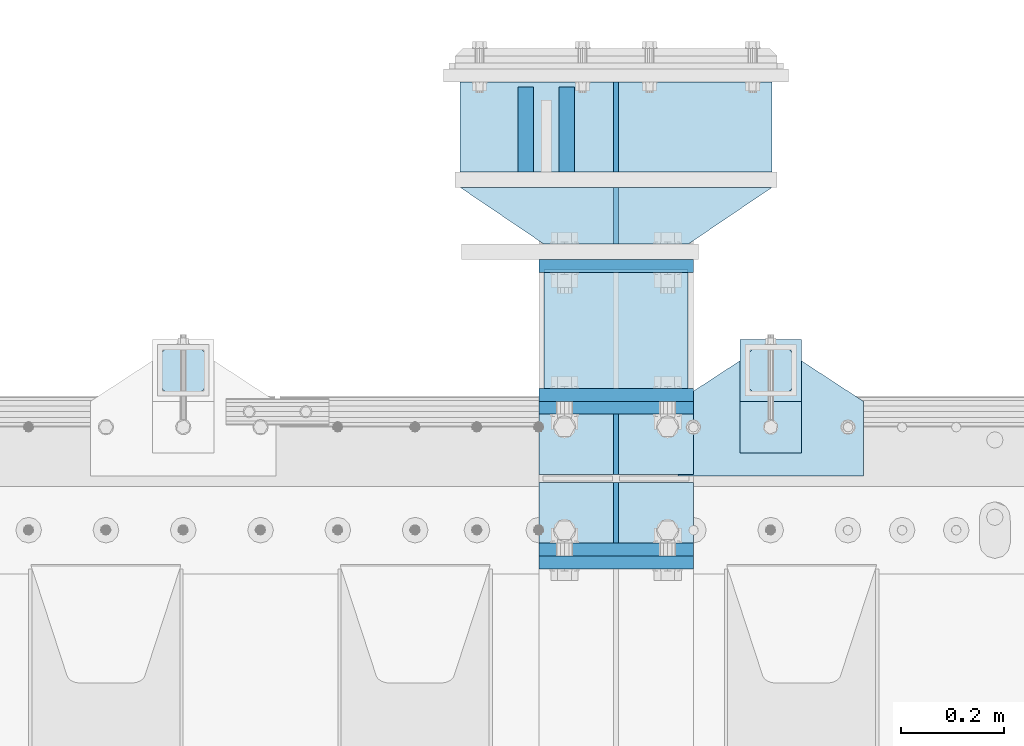
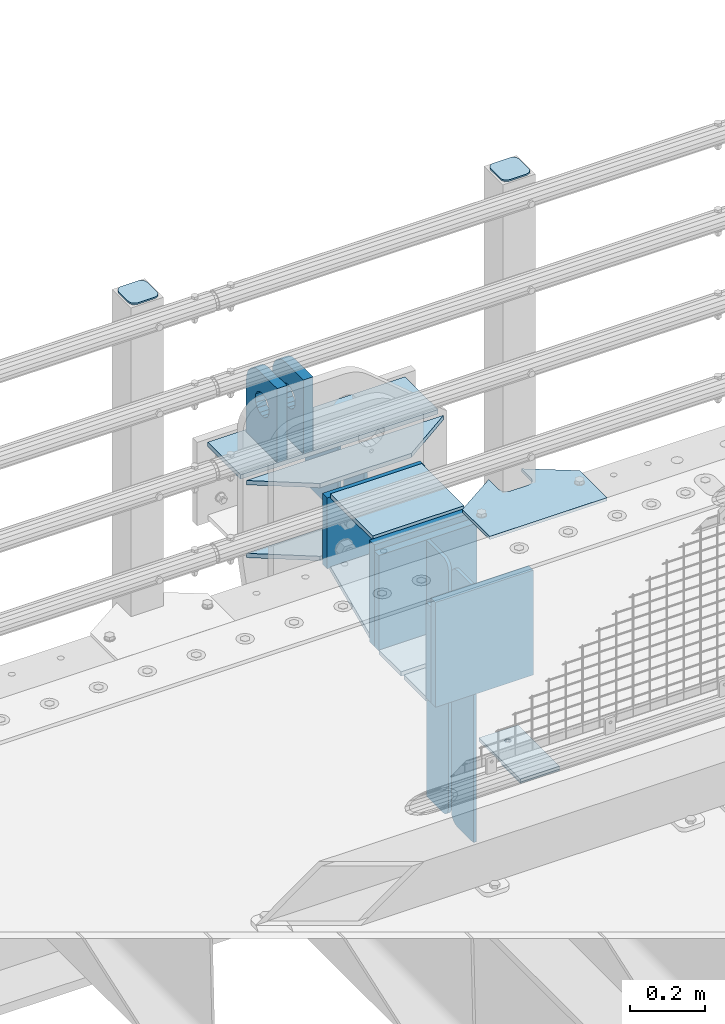
# One storey, part 175 of 193: 25 plates.
"""IFC2X3 building model written with IfcOpenShell, lengths in millimetres."""

from ifc_helpers import new_model, si_unit, frame, origin_with_axes, place, context, subcontext, project, spatial, faceted_brep, material, type_object, element, save


model = new_model("IFC2X3")

# Units and contexts
model_context = context("Model", 3, precision=1e-05, world=origin_with_axes())
body_context = subcontext(model_context, "Body", "Model", "MODEL_VIEW")
ifc_project = project(units=[si_unit("LENGTHUNIT", "METRE", prefix="MILLI"), si_unit("AREAUNIT", "SQUARE_METRE"), si_unit("VOLUMEUNIT", "CUBIC_METRE"), si_unit("MASSUNIT", "GRAM", prefix="KILO"), si_unit("TIMEUNIT", "SECOND"), si_unit("PLANEANGLEUNIT", "RADIAN"), si_unit("SOLIDANGLEUNIT", "STERADIAN"), si_unit("THERMODYNAMICTEMPERATUREUNIT", "DEGREE_CELSIUS"), si_unit("LUMINOUSINTENSITYUNIT", "LUMEN")], contexts=[model_context])

# Site, building, storey
site_placement = place(None, origin_with_axes())
site = spatial("IfcSite", under=ifc_project, at=site_placement, CompositionType="ELEMENT")
building_placement = place(site_placement, origin_with_axes())
building = spatial("IfcBuilding", under=site, at=building_placement, Name="Standard", CompositionType="ELEMENT")
storey_placement = place(building_placement, origin_with_axes())
storey = spatial("IfcBuildingStorey", under=building, at=storey_placement, Name="Undefined", CompositionType="ELEMENT", Elevation=0.0)

# Plates
ifc_material_1 = material(Name="STEEL/S355N")
plate_type_1 = type_object("IfcPlateType", PredefinedType="NOTDEFINED")
plate_1_placement = place(storey_placement, frame((-32200.0000000678, 30175.0000000043, -7.00001823835851), z_axis=(0.0, 1.0, 0.0), x_axis=(1.0, 0.0, 0.0)))
element("IfcPlate", 1, at=plate_1_placement, inside=storey, type_object=plate_type_1, material=ifc_material_1, context=body_context, shape_type="Brep", body=[
    faceted_brep([(0.0, -7.0, 0.0), (0.0, -7.0, 225.0), (0.0, 7.0, 225.0), (0.0, 7.0, 0.0), (280.0, -7.0, 225.0), (280.0, 7.0, 225.0), (280.0, -7.0, 0.0), (280.0, 7.0, 0.0)], [[[0, 1, 2, 3]], [[1, 4, 5, 2]], [[4, 6, 7, 5]], [[6, 0, 3, 7]], [[5, 7, 3, 2]], [[6, 4, 1, 0]]]),
])
plate_type_2 = type_object("IfcPlateType", PredefinedType="NOTDEFINED")
plate_2_placement = place(storey_placement, frame((-32060.0000000678, 30770.0000000043, -14.0000182383585), z_axis=(0.0, 0.0, -1.0), x_axis=(0.0, -1.0, 0.0)))
element("IfcPlate", 2, at=plate_2_placement, inside=storey, type_object=plate_type_2, material=ifc_material_1, context=body_context, shape_type="Brep", body=[
    faceted_brep([(0.0, -5.0, 0.0), (0.0, -5.0, 222.0), (0.0, 5.0, 222.0), (0.0, 5.0, 0.0), (175.0, -5.0, 222.0), (175.0, 5.0, 222.0), (175.0, -5.0, 0.0), (175.0, 5.0, 0.0)], [[[0, 1, 2, 3]], [[1, 4, 5, 2]], [[4, 6, 7, 5]], [[6, 0, 3, 7]], [[5, 7, 3, 2]], [[6, 4, 1, 0]]]),
])
plate_type_3 = type_object("IfcPlateType", PredefinedType="NOTDEFINED")
plate_3_placement = place(storey_placement, frame((-32155.5000000678, 30595.0000000043, -1.82383585070056e-05), z_axis=(0.0, 1.0, 0.0), x_axis=(0.0, 0.0, 1.0)))
element("IfcPlate", 3, at=plate_3_placement, inside=storey, type_object=plate_type_3, material=ifc_material_1, context=body_context, shape_type="Brep", body=[
    faceted_brep([(113.837049096103, -14.9999989400749, 106.162951053899), (113.837049096103, 15.0000010599251, 106.162950753896), (125.840713002497, 15.0000011401316, 114.183542552913), (125.840713002497, -14.9999988598684, 114.183542852916), (105.816457297088, -14.99999906011, 94.1592871475041), (105.816457297088, 15.00000093989, 94.1592868475018), (103.000000000005, -14.9999992017038, 80.0000001499975), (103.000000000005, 15.0000007982962, 79.9999998499952), (105.816457297088, -14.9999993432975, 65.8407131524909), (105.816457297088, 15.0000006567025, 65.8407128524887), (113.837049096103, -14.9999994633326, 53.8370492460963), (113.837049096103, 15.0000005366674, 53.837048946094), (125.840713002497, -14.9999995435392, 45.8164574470793), (125.840713002497, 15.0000004564608, 45.816457147077), (140.000000000005, -14.9999995717044, 43.0000001499975), (140.000000000005, 15.0000004282956, 42.9999998499952), (154.159286997514, -14.9999995435392, 45.8164574470793), (154.159286997514, 15.0000004564608, 45.816457147077), (166.162950903908, -14.9999994633326, 53.8370492460963), (166.162950903908, 15.0000005366674, 53.837048946094), (174.183542702923, -14.9999993432975, 65.8407131524909), (174.183542702923, 15.0000006567025, 65.8407128524887), (177.000000000005, -14.9999992017038, 80.0000001499975), (177.000000000005, 15.0000007982962, 79.9999998499952), (174.183542702923, -14.99999906011, 94.1592871475041), (174.183542702923, 15.00000093989, 94.1592868475018), (166.162950903908, -14.9999989400749, 106.162951053899), (166.162950903908, 15.0000010599251, 106.162950753896), (154.159286997514, -14.9999988598684, 114.183542852916), (154.159286997514, 15.0000011401316, 114.183542552913), (140.000000000005, -14.9999988317031, 117.000000149998), (140.000000000005, 15.0000011682969, 116.999999849995), (-1.40620068123098e-06, -15.0, 164.999999999996), (170.0, -15.0, 165.0), (170.0, 15.0, 165.0), (-1.40620068123098e-06, 15.0, 164.999999999996), (188.117333157176, -15.0, 162.614807840237), (188.117333157176, 15.0, 162.614807840237), (205.0, -15.0, 155.621778264911), (205.0, 15.0, 155.621778264911), (219.497474683058, -15.0, 144.497474683059), (219.497474683058, 15.0, 144.497474683059), (230.621778264911, -15.0, 130.0), (230.621778264911, 15.0, 130.0), (237.614807840235, -15.0, 113.117333157177), (237.614807840235, 15.0, 113.117333157177), (240.0, -15.0, 95.0), (240.0, 15.0, 95.0), (240.000015258789, -14.9999999999964, -2.07364792004228e-10), (240.000015258789, 15.0000000000036, -2.11002770811319e-10), (0.0, -15.0, 0.0), (0.0, 15.0, 0.0)], [[[0, 1, 2, 3]], [[4, 5, 1, 0]], [[6, 7, 5, 4]], [[8, 9, 7, 6]], [[10, 11, 9, 8]], [[12, 13, 11, 10]], [[14, 15, 13, 12]], [[16, 17, 15, 14]], [[18, 19, 17, 16]], [[20, 21, 19, 18]], [[22, 23, 21, 20]], [[24, 25, 23, 22]], [[26, 27, 25, 24]], [[28, 29, 27, 26]], [[30, 31, 29, 28]], [[3, 2, 31, 30]], [[32, 33, 34, 35]], [[33, 36, 37, 34]], [[36, 38, 39, 37]], [[38, 40, 41, 39]], [[40, 42, 43, 41]], [[42, 44, 45, 43]], [[44, 46, 47, 45]], [[46, 48, 49, 47]], [[48, 50, 51, 49]], [[34, 37, 39, 41, 43, 45, 47, 49, 51, 35], [19, 21, 23, 25, 27, 29, 31, 2, 1, 5, 7, 9, 11, 13, 15, 17]], [[50, 32, 35, 51]], [[48, 46, 44, 42, 40, 38, 36, 33, 32, 50], [10, 8, 6, 4, 0, 3, 30, 28, 26, 24, 22, 20, 18, 16, 14, 12]]]),
])
plate_4_placement = place(storey_placement, frame((-32235.5000000678, 30595.0000000043, -1.82383585070056e-05), z_axis=(0.0, 1.0, 0.0), x_axis=(0.0, 0.0, 1.0)))
element("IfcPlate", 4, at=plate_4_placement, inside=storey, type_object=plate_type_3, material=ifc_material_1, context=body_context, shape_type="Brep", body=[
    faceted_brep([(113.837049096103, -14.9999989400749, 106.162951053899), (113.837049096103, 15.0000010599251, 106.162950753896), (125.840713002497, 15.0000011401316, 114.183542552913), (125.840713002497, -14.9999988598684, 114.183542852916), (105.816457297088, -14.99999906011, 94.1592871475041), (105.816457297088, 15.00000093989, 94.1592868475018), (103.000000000005, -14.9999992017038, 80.0000001499975), (103.000000000005, 15.0000007982962, 79.9999998499952), (105.816457297088, -14.9999993432975, 65.8407131524909), (105.816457297088, 15.0000006567025, 65.8407128524887), (113.837049096103, -14.9999994633326, 53.8370492460963), (113.837049096103, 15.0000005366674, 53.837048946094), (125.840713002497, -14.9999995435392, 45.8164574470793), (125.840713002497, 15.0000004564608, 45.816457147077), (140.000000000005, -14.9999995717044, 43.0000001499975), (140.000000000005, 15.0000004282956, 42.9999998499952), (154.159286997514, -14.9999995435392, 45.8164574470793), (154.159286997514, 15.0000004564608, 45.816457147077), (166.162950903908, -14.9999994633326, 53.8370492460963), (166.162950903908, 15.0000005366674, 53.837048946094), (174.183542702923, -14.9999993432975, 65.8407131524909), (174.183542702923, 15.0000006567025, 65.8407128524887), (177.000000000005, -14.9999992017038, 80.0000001499975), (177.000000000005, 15.0000007982962, 79.9999998499952), (174.183542702923, -14.99999906011, 94.1592871475041), (174.183542702923, 15.00000093989, 94.1592868475018), (166.162950903908, -14.9999989400749, 106.162951053899), (166.162950903908, 15.0000010599251, 106.162950753896), (154.159286997514, -14.9999988598684, 114.183542852916), (154.159286997514, 15.0000011401316, 114.183542552913), (140.000000000005, -14.9999988317031, 117.000000149998), (140.000000000005, 15.0000011682969, 116.999999849995), (-1.40620068123098e-06, -15.0, 164.999999999996), (170.0, -15.0, 165.0), (170.0, 15.0, 165.0), (-1.40620068123098e-06, 15.0, 164.999999999996), (188.117333157176, -15.0, 162.614807840237), (188.117333157176, 15.0, 162.614807840237), (205.0, -15.0, 155.621778264911), (205.0, 15.0, 155.621778264911), (219.497474683058, -15.0, 144.497474683059), (219.497474683058, 15.0, 144.497474683059), (230.621778264911, -15.0, 130.0), (230.621778264911, 15.0, 130.0), (237.614807840235, -15.0, 113.117333157177), (237.614807840235, 15.0, 113.117333157177), (240.0, -15.0, 95.0), (240.0, 15.0, 95.0), (240.000015258789, -14.9999999999964, -2.07364792004228e-10), (240.000015258789, 15.0000000000036, -2.11002770811319e-10), (0.0, -15.0, 0.0), (0.0, 15.0, 0.0)], [[[0, 1, 2, 3]], [[4, 5, 1, 0]], [[6, 7, 5, 4]], [[8, 9, 7, 6]], [[10, 11, 9, 8]], [[12, 13, 11, 10]], [[14, 15, 13, 12]], [[16, 17, 15, 14]], [[18, 19, 17, 16]], [[20, 21, 19, 18]], [[22, 23, 21, 20]], [[24, 25, 23, 22]], [[26, 27, 25, 24]], [[28, 29, 27, 26]], [[30, 31, 29, 28]], [[3, 2, 31, 30]], [[32, 33, 34, 35]], [[33, 36, 37, 34]], [[36, 38, 39, 37]], [[38, 40, 41, 39]], [[40, 42, 43, 41]], [[42, 44, 45, 43]], [[44, 46, 47, 45]], [[46, 48, 49, 47]], [[48, 50, 51, 49]], [[34, 37, 39, 41, 43, 45, 47, 49, 51, 35], [19, 21, 23, 25, 27, 29, 31, 2, 1, 5, 7, 9, 11, 13, 15, 17]], [[50, 32, 35, 51]], [[48, 46, 44, 42, 40, 38, 36, 33, 32, 50], [10, 8, 6, 4, 0, 3, 30, 28, 26, 24, 22, 20, 18, 16, 14, 12]]]),
])
plate_type_4 = type_object("IfcPlateType", PredefinedType="NOTDEFINED")
plate_5_placement = place(storey_placement, frame((-32210.0000000678, 30162.5000000043, -340.000018238358), z_axis=(0.0, 0.0, 1.0), x_axis=(1.0, 0.0, 0.0)))
element("IfcPlate", 5, at=plate_5_placement, inside=storey, type_object=plate_type_4, material=ifc_material_1, context=body_context, shape_type="Brep", body=[
    faceted_brep([(0.0, -12.5, 0.0), (0.0, -12.5, 330.0), (0.0, 12.5, 330.0), (0.0, 12.5, 0.0), (300.0, -12.5, 330.0), (300.0, 12.5, 330.0), (300.0, -12.5, 0.0), (300.0, 12.5, 0.0)], [[[0, 1, 2, 3]], [[1, 4, 5, 2]], [[4, 6, 7, 5]], [[6, 0, 3, 7]], [[5, 7, 3, 2]], [[6, 4, 1, 0]]]),
])
plate_6_placement = place(storey_placement, frame((-32210.0, 29837.5, -340.000000000044), z_axis=(0.0, 0.0, 1.0), x_axis=(1.0, 0.0, 0.0)))
element("IfcPlate", 6, at=plate_6_placement, inside=storey, type_object=plate_type_4, material=ifc_material_1, context=body_context, shape_type="Brep", body=[
    faceted_brep([(0.0, -12.5, 0.0), (9.27684595808387e-10, -12.5, 340.0), (9.27684595808387e-10, 12.5, 340.0), (0.0, 12.5, 0.0), (300.0, -12.5, 340.0), (300.0, 12.5, 340.0), (300.0, -12.5, 0.0), (300.0, 12.5, 0.0)], [[[0, 1, 2, 3]], [[1, 4, 5, 2]], [[4, 6, 7, 5]], [[6, 0, 3, 7]], [[5, 7, 3, 2]], [[6, 4, 1, 0]]]),
])
for number, where, z_axis, x_axis in (
    (7, (-32210.0, 30137.5, -340.0), (0.0, 0.0, 1.0), (1.0, 0.0, 0.0)),
    (8, (-32210.0, 29862.5, -340.0), (0.0, 0.0, 1.0), (1.0, 0.0, 0.0)),
):
    element("IfcPlate", number, at=place(storey_placement, frame(where, z_axis=z_axis, x_axis=x_axis)), inside=storey, type_object=plate_type_4, material=ifc_material_1, context=body_context, shape_type="Brep", body=[
        faceted_brep([(0.0, -12.5, 0.0), (0.0, -12.5, 310.0), (0.0, 12.5, 310.0), (0.0, 12.5, 0.0), (300.0, -12.5, 310.0), (300.0, 12.5, 310.0), (300.0, -12.5, 0.0), (300.0, 12.5, 0.0)], [[[0, 1, 2, 3]], [[1, 4, 5, 2]], [[4, 6, 7, 5]], [[6, 0, 3, 7]], [[5, 7, 3, 2]], [[6, 4, 1, 0]]]),
    ])
plate_type_5 = type_object("IfcPlateType", PredefinedType="NOTDEFINED")
for number, where, z_axis, x_axis in (
    (9, (-32210.0, 29992.0, -343.0), (0.0, -1.0, 0.0), (1.0, 0.0, 0.0)),
    (10, (-32210.0, 30008.0, -343.0), (0.0, 1.0, 0.0), (1.0, 0.0, 0.0)),
):
    element("IfcPlate", number, at=place(storey_placement, frame(where, z_axis=z_axis, x_axis=x_axis)), inside=storey, type_object=plate_type_5, material=ifc_material_1, context=body_context, shape_type="Brep", body=[
        faceted_brep([(0.0, -7.0, 0.0), (0.0, -7.0, 117.0), (0.0, 7.0, 117.0), (0.0, 7.0, 0.0), (300.0, -7.0, 117.0), (300.0, 7.0, 117.0), (300.0, -7.0, 0.0), (300.0, 7.0, 0.0)], [[[0, 1, 2, 3]], [[1, 4, 5, 2]], [[4, 6, 7, 5]], [[6, 0, 3, 7]], [[5, 7, 3, 2]], [[6, 4, 1, 0]]]),
    ])
plate_type_6 = type_object("IfcPlateType", PredefinedType="NOTDEFINED")
for number, where, z_axis, x_axis in (
    (11, (-32060.0, 30008.0, -30.0), (0.0, 0.0, -1.0), (0.0, 1.0, 0.0)),
    (12, (-32060.0, 29992.0, -30.0), (0.0, 0.0, -1.0), (0.0, -1.0, 0.0)),
):
    element("IfcPlate", number, at=place(storey_placement, frame(where, z_axis=z_axis, x_axis=x_axis)), inside=storey, type_object=plate_type_6, material=ifc_material_1, context=body_context, shape_type="Brep", body=[
        faceted_brep([(0.0, -5.0, 30.0), (0.0, -5.0, 306.0), (0.0, 5.0, 306.0), (0.0, 5.0, 30.0), (117.0, -5.0, 306.0), (117.0, 5.0, 306.0), (117.0, -5.0, 0.0), (117.0, 5.0, 0.0), (30.0, -5.0, 0.0), (30.0, 5.0, 0.0), (24.7905546699913, -5.0, 0.455767409633758), (24.7905546699913, 5.0, 0.455767409633758), (19.7393957002314, -5.0, 1.80922137642275), (19.7393957002314, 5.0, 1.80922137642275), (15.0, -5.0, 4.01923788646684), (15.0, 5.0, 4.01923788646684), (10.7163717094045, -5.0, 7.01866670643066), (10.7163717094045, 5.0, 7.01866670643066), (7.01866670642994, -5.0, 10.7163717094038), (7.01866670642994, 5.0, 10.7163717094038), (4.01923788646673, -5.0, 15.0), (4.01923788646673, 5.0, 15.0), (1.80922137642119, -5.0, 19.7393957002299), (1.80922137642119, 5.0, 19.7393957002299), (0.455767409632244, -5.0, 24.7905546699921), (0.455767409632244, 5.0, 24.7905546699921)], [[[0, 1, 2, 3]], [[1, 4, 5, 2]], [[4, 6, 7, 5]], [[6, 8, 9, 7]], [[8, 10, 11, 9]], [[10, 12, 13, 11]], [[12, 14, 15, 13]], [[14, 16, 17, 15]], [[16, 18, 19, 17]], [[18, 20, 21, 19]], [[20, 22, 23, 21]], [[22, 24, 25, 23]], [[24, 0, 3, 25]], [[5, 7, 9, 11, 13, 15, 17, 19, 21, 23, 25, 3, 2]], [[24, 22, 20, 18, 16, 14, 12, 10, 8, 6, 4, 1, 0]]]),
    ])
for number, where, z_axis, x_axis in (
    (13, (-32060.0, 29992.0, -350.0), (0.0, 0.0, -1.0), (0.0, -1.0, 0.0)),
    (14, (-32060.0, 30008.0, -350.0), (0.0, 0.0, -1.0), (0.0, 1.0, 0.0)),
):
    element("IfcPlate", number, at=place(storey_placement, frame(where, z_axis=z_axis, x_axis=x_axis)), inside=storey, type_object=plate_type_6, material=ifc_material_1, context=body_context, shape_type="Brep", body=[
        faceted_brep([(0.0, -5.0, 0.0), (0.0, -5.0, 480.0), (0.0, 5.0, 480.0), (0.0, 5.0, 0.0), (0.455767409632244, -5.0, 485.209445330008), (0.455767409632244, 5.0, 485.209445330008), (1.80922137642119, -5.0, 490.26060429977), (1.80922137642119, 5.0, 490.26060429977), (4.01923788646673, -5.0, 495.0), (4.01923788646673, 5.0, 495.0), (7.01866670642994, -5.0, 499.283628290596), (7.01866670642994, 5.0, 499.283628290596), (10.7163717094045, -5.0, 502.981333293569), (10.7163717094045, 5.0, 502.981333293569), (15.0, -5.0, 505.980762113533), (15.0, 5.0, 505.980762113533), (19.7393957002314, -5.0, 508.190778623577), (19.7393957002314, 5.0, 508.190778623577), (24.7905546699913, -5.0, 509.544232590366), (24.7905546699913, 5.0, 509.544232590366), (30.0, -5.0, 510.0), (30.0, 5.0, 510.0), (117.0, -5.0, 510.0), (117.0, 5.0, 510.0), (117.0, -5.0, 0.0), (117.0, 5.0, 0.0)], [[[0, 1, 2, 3]], [[1, 4, 5, 2]], [[4, 6, 7, 5]], [[6, 8, 9, 7]], [[8, 10, 11, 9]], [[10, 12, 13, 11]], [[12, 14, 15, 13]], [[14, 16, 17, 15]], [[16, 18, 19, 17]], [[18, 20, 21, 19]], [[20, 22, 23, 21]], [[22, 24, 25, 23]], [[24, 0, 3, 25]], [[5, 7, 9, 11, 13, 15, 17, 19, 21, 23, 25, 3, 2]], [[24, 22, 20, 18, 16, 14, 12, 10, 8, 6, 4, 1, 0]]]),
    ])
ifc_material_2 = material(Name="STEEL/S355J2")
plate_type_7 = type_object("IfcPlateType", PredefinedType="NOTDEFINED")
plate_7_placement = place(storey_placement, frame((-31940.0, 30005.0, 5.00000000004911), z_axis=(0.0, 1.0, 0.0), x_axis=(1.0, 0.0, 0.0)))
element("IfcPlate", 15, at=plate_7_placement, inside=storey, type_object=plate_type_7, material=ifc_material_2, context=body_context, shape_type="Brep", body=[
    faceted_brep([(0.0, -5.0, 0.0), (2.31396552408114e-06, -5.0, 145.0), (2.31396552408114e-06, 5.0, 145.0), (0.0, 5.0, 0.0), (130.0, -5.0, 230.0), (130.0, 5.0, 230.0), (130.0, -5.0, 180.0), (130.0, 5.0, 180.0), (130.48036798992, -5.0, 175.122741949595), (130.48036798992, 5.0, 175.122741949595), (131.903011687216, -5.0, 170.432914190871), (131.903011687216, 5.0, 170.432914190871), (134.213259692435, -5.0, 166.110744174512), (134.213259692435, 5.0, 166.110744174512), (137.322330470335, -5.0, 162.322330470335), (137.322330470335, 5.0, 162.322330470335), (141.110744174512, -5.0, 159.213259692435), (141.110744174512, 5.0, 159.213259692435), (145.432914190871, -5.0, 156.903011687216), (145.432914190871, 5.0, 156.903011687216), (150.122741949595, -5.0, 155.48036798992), (150.122741949595, 5.0, 155.48036798992), (155.0, -5.0, 155.0), (155.0, 5.0, 155.0), (205.0, -5.0, 155.0), (205.0, 5.0, 155.0), (209.877258050405, -5.0, 155.48036798992), (209.877258050405, 5.0, 155.48036798992), (214.567085809129, -5.0, 156.903011687216), (214.567085809129, 5.0, 156.903011687216), (218.889255825488, -5.0, 159.213259692435), (218.889255825488, 5.0, 159.213259692435), (222.677669529665, -5.0, 162.322330470335), (222.677669529665, 5.0, 162.322330470335), (225.786740307565, -5.0, 166.110744174512), (225.786740307565, 5.0, 166.110744174512), (228.096988312784, -5.0, 170.432914190871), (228.096988312784, 5.0, 170.432914190871), (229.51963201008, -5.0, 175.122741949595), (229.51963201008, 5.0, 175.122741949595), (230.0, -5.0, 180.0), (230.0, 5.0, 180.0), (230.0, -5.0, 230.0), (230.0, 5.0, 230.0), (360.0, -5.0, 145.0), (360.0, 5.0, 145.0), (360.0, -5.0, -7.27595761418343e-12), (360.0, 5.0, -7.27595761418343e-12)], [[[0, 1, 2, 3]], [[1, 4, 5, 2]], [[4, 6, 7, 5]], [[6, 8, 9, 7]], [[8, 10, 11, 9]], [[10, 12, 13, 11]], [[12, 14, 15, 13]], [[14, 16, 17, 15]], [[16, 18, 19, 17]], [[18, 20, 21, 19]], [[20, 22, 23, 21]], [[22, 24, 25, 23]], [[24, 26, 27, 25]], [[26, 28, 29, 27]], [[28, 30, 31, 29]], [[30, 32, 33, 31]], [[32, 34, 35, 33]], [[34, 36, 37, 35]], [[36, 38, 39, 37]], [[38, 40, 41, 39]], [[40, 42, 43, 41]], [[42, 44, 45, 43]], [[44, 46, 47, 45]], [[46, 0, 3, 47]], [[5, 7, 9, 11, 13, 15, 17, 19, 21, 23, 25, 27, 29, 31, 33, 35, 37, 39, 41, 43, 45, 47, 3, 2]], [[46, 44, 42, 40, 38, 36, 34, 32, 30, 28, 26, 24, 22, 20, 18, 16, 14, 12, 10, 8, 6, 4, 1, 0]]]),
])
plate_type_8 = type_object("IfcPlateType", PredefinedType="NOTDEFINED")
plate_8_placement = place(storey_placement, frame((-31819.9999999999, 30050.0000000002, -850.000000000002), z_axis=(0.0, 1.0, 0.0), x_axis=(1.0, 0.0, 0.0)))
element("IfcPlate", 16, at=plate_8_placement, inside=storey, type_object=plate_type_8, material=ifc_material_2, context=body_context, shape_type="Brep", body=[
    faceted_brep([(66.3639610305399, -5.0, 163.636038969111), (66.3639610305399, 5.0, 163.636038969111), (59.9999999998618, 5.0, 160.999999999789), (59.9999999998618, -5.0, 160.999999999789), (53.6360389691836, 5.0, 163.636038969111), (53.6360389691836, -5.0, 163.636038969111), (50.9999999998618, 5.0, 169.999999999789), (50.9999999998618, -5.0, 169.999999999789), (53.6360389691836, 5.0, 176.363961030467), (53.6360389691836, -5.0, 176.363961030467), (59.9999999998618, 5.0, 178.999999999789), (59.9999999998618, -5.0, 178.999999999789), (66.3639610305399, 5.0, 176.363961030467), (66.3639610305399, -5.0, 176.363961030467), (68.9999999998618, 5.0, 169.999999999789), (68.9999999998618, -5.0, 169.999999999789), (120.0, -5.0, 0.0), (120.0, -5.0, 220.0), (0.0, -5.0, 220.0), (0.0, -5.0, 0.0), (0.0, 5.0, 0.0), (120.0, 5.0, 0.0), (120.0, 5.0, 220.0), (0.0, 5.0, 220.0)], [[[0, 1, 2, 3]], [[3, 2, 4, 5]], [[5, 4, 6, 7]], [[7, 6, 8, 9]], [[9, 8, 10, 11]], [[11, 10, 12, 13]], [[13, 12, 14, 15]], [[15, 14, 1, 0]], [[16, 17, 18, 19], [3, 5, 7, 9, 11, 13, 15, 0]], [[16, 19, 20, 21]], [[17, 16, 21, 22]], [[18, 17, 22, 23]], [[19, 18, 23, 20]], [[22, 21, 20, 23], [10, 8, 6, 4, 2, 1, 14, 12]]]),
])
plate_type_9 = type_object("IfcPlateType", PredefinedType="NOTDEFINED")
plate_9_placement = place(storey_placement, frame((-31715.9999999999, 30166.0000000002, 1012.50000000001), z_axis=(0.0, 1.0, 0.0), x_axis=(-1.0, 0.0, 0.0)))
element("IfcPlate", 17, at=plate_9_placement, inside=storey, type_object=plate_type_9, material=ifc_material_2, context=body_context, shape_type="Brep", body=[
    faceted_brep([(0.0, -2.5, 19.0), (0.0, -2.5, 69.0), (0.0, 2.5, 69.0), (0.0, 2.5, 19.0), (0.476369668544066, -2.5, 73.2278977451715), (0.476369668544066, 2.5, 73.2278977451715), (1.88159150985302, -2.5, 77.2437910432345), (1.88159150985302, 2.5, 77.2437910432345), (4.14520183310742, -2.5, 80.8463062353148), (4.14520183310742, 2.5, 80.8463062353148), (7.15369376468516, -2.5, 83.8547981668926), (7.15369376468516, 2.5, 83.8547981668926), (10.7562089567655, -2.5, 86.118408490147), (10.7562089567655, 2.5, 86.118408490147), (14.7721022548285, -2.5, 87.5236303314559), (14.7721022548285, 2.5, 87.5236303314559), (19.0, -2.5, 88.0), (19.0, 2.5, 88.0), (69.0, -2.5, 88.0), (69.0, 2.5, 88.0), (73.2278977451715, -2.5, 87.5236303314559), (73.2278977451715, 2.5, 87.5236303314559), (77.2437910432345, -2.5, 86.118408490147), (77.2437910432345, 2.5, 86.118408490147), (80.8463062353148, -2.5, 83.8547981668926), (80.8463062353148, 2.5, 83.8547981668926), (83.8547981668926, -2.5, 80.8463062353148), (83.8547981668926, 2.5, 80.8463062353148), (86.118408490147, -2.5, 77.2437910432345), (86.118408490147, 2.5, 77.2437910432345), (87.5236303314559, -2.5, 73.2278977451715), (87.5236303314559, 2.5, 73.2278977451715), (88.0, -2.5, 69.0), (88.0, 2.5, 69.0), (88.0, -2.5, 19.0), (88.0, 2.5, 19.0), (87.5236303314559, -2.5, 14.7721022548285), (87.5236303314559, 2.5, 14.7721022548285), (86.118408490147, -2.5, 10.7562089567655), (86.118408490147, 2.5, 10.7562089567655), (83.8547981668926, -2.5, 7.15369376468516), (83.8547981668926, 2.5, 7.15369376468516), (80.8463062353148, -2.5, 4.14520183310742), (80.8463062353148, 2.5, 4.14520183310742), (77.2437910432345, -2.5, 1.88159150985302), (77.2437910432345, 2.5, 1.88159150985302), (73.2278977451715, -2.5, 0.476369668544066), (73.2278977451715, 2.5, 0.476369668544066), (69.0, -2.5, 0.0), (69.0, 2.5, 0.0), (19.0, -2.5, 0.0), (19.0, 2.5, 0.0), (14.7721022548285, -2.5, 0.476369668544066), (14.7721022548285, 2.5, 0.476369668544066), (10.7562089567655, -2.5, 1.88159150985302), (10.7562089567655, 2.5, 1.88159150985302), (7.15369376468516, -2.5, 4.14520183310742), (7.15369376468516, 2.5, 4.14520183310742), (4.14520183310742, -2.5, 7.15369376468516), (4.14520183310742, 2.5, 7.15369376468516), (1.88159150985302, -2.5, 10.7562089567655), (1.88159150985302, 2.5, 10.7562089567655), (0.476369668544066, -2.5, 14.7721022548285), (0.476369668544066, 2.5, 14.7721022548285)], [[[0, 1, 2, 3]], [[1, 4, 5, 2]], [[4, 6, 7, 5]], [[6, 8, 9, 7]], [[8, 10, 11, 9]], [[10, 12, 13, 11]], [[12, 14, 15, 13]], [[14, 16, 17, 15]], [[16, 18, 19, 17]], [[18, 20, 21, 19]], [[20, 22, 23, 21]], [[22, 24, 25, 23]], [[24, 26, 27, 25]], [[26, 28, 29, 27]], [[28, 30, 31, 29]], [[30, 32, 33, 31]], [[32, 34, 35, 33]], [[34, 36, 37, 35]], [[36, 38, 39, 37]], [[38, 40, 41, 39]], [[40, 42, 43, 41]], [[42, 44, 45, 43]], [[44, 46, 47, 45]], [[46, 48, 49, 47]], [[48, 50, 51, 49]], [[50, 52, 53, 51]], [[52, 54, 55, 53]], [[54, 56, 57, 55]], [[56, 58, 59, 57]], [[58, 60, 61, 59]], [[60, 62, 63, 61]], [[62, 0, 3, 63]], [[5, 7, 9, 11, 13, 15, 17, 19, 21, 23, 25, 27, 29, 31, 33, 35, 37, 39, 41, 43, 45, 47, 49, 51, 53, 55, 57, 59, 61, 63, 3, 2]], [[62, 60, 58, 56, 54, 52, 50, 48, 46, 44, 42, 40, 38, 36, 34, 32, 30, 28, 26, 24, 22, 20, 18, 16, 14, 12, 10, 8, 6, 4, 1, 0]]]),
])
plate_10_placement = place(storey_placement, frame((-32855.9999999999, 30166.0000000002, 1012.50000000001), z_axis=(0.0, 1.0, 0.0), x_axis=(-1.0, 0.0, 0.0)))
element("IfcPlate", 18, at=plate_10_placement, inside=storey, type_object=plate_type_9, material=ifc_material_2, context=body_context, shape_type="Brep", body=[
    faceted_brep([(0.0, -2.5, 19.0), (0.0, -2.5, 69.0), (0.0, 2.5, 69.0), (0.0, 2.5, 19.0), (0.476369668544066, -2.5, 73.2278977451715), (0.476369668544066, 2.5, 73.2278977451715), (1.88159150985302, -2.5, 77.2437910432345), (1.88159150985302, 2.5, 77.2437910432345), (4.14520183310742, -2.5, 80.8463062353148), (4.14520183310742, 2.5, 80.8463062353148), (7.15369376468516, -2.5, 83.8547981668926), (7.15369376468516, 2.5, 83.8547981668926), (10.7562089567655, -2.5, 86.118408490147), (10.7562089567655, 2.5, 86.118408490147), (14.7721022548285, -2.5, 87.5236303314559), (14.7721022548285, 2.5, 87.5236303314559), (19.0, -2.5, 88.0), (19.0, 2.5, 88.0), (69.0, -2.5, 88.0), (69.0, 2.5, 88.0), (73.2278977451715, -2.5, 87.5236303314559), (73.2278977451715, 2.5, 87.5236303314559), (77.2437910432345, -2.5, 86.118408490147), (77.2437910432345, 2.5, 86.118408490147), (80.8463062353148, -2.5, 83.8547981668926), (80.8463062353148, 2.5, 83.8547981668926), (83.8547981668926, -2.5, 80.8463062353148), (83.8547981668926, 2.5, 80.8463062353148), (86.118408490147, -2.5, 77.2437910432345), (86.118408490147, 2.5, 77.2437910432345), (87.5236303314559, -2.5, 73.2278977451715), (87.5236303314559, 2.5, 73.2278977451715), (88.0, -2.5, 69.0), (88.0, 2.5, 69.0), (88.0, -2.5, 19.0), (88.0, 2.5, 19.0), (87.5236303314559, -2.5, 14.7721022548285), (87.5236303314559, 2.5, 14.7721022548285), (86.118408490147, -2.5, 10.7562089567655), (86.118408490147, 2.5, 10.7562089567655), (83.8547981668926, -2.5, 7.15369376468516), (83.8547981668926, 2.5, 7.15369376468516), (80.8463062353148, -2.5, 4.14520183310742), (80.8463062353148, 2.5, 4.14520183310742), (77.2437910432345, -2.5, 1.88159150985302), (77.2437910432345, 2.5, 1.88159150985302), (73.2278977451715, -2.5, 0.476369668544066), (73.2278977451715, 2.5, 0.476369668544066), (69.0, -2.5, 0.0), (69.0, 2.5, 0.0), (19.0, -2.5, 0.0), (19.0, 2.5, 0.0), (14.7721022548285, -2.5, 0.476369668544066), (14.7721022548285, 2.5, 0.476369668544066), (10.7562089567655, -2.5, 1.88159150985302), (10.7562089567655, 2.5, 1.88159150985302), (7.15369376468516, -2.5, 4.14520183310742), (7.15369376468516, 2.5, 4.14520183310742), (4.14520183310742, -2.5, 7.15369376468516), (4.14520183310742, 2.5, 7.15369376468516), (1.88159150985302, -2.5, 10.7562089567655), (1.88159150985302, 2.5, 10.7562089567655), (0.476369668544066, -2.5, 14.7721022548285), (0.476369668544066, 2.5, 14.7721022548285)], [[[0, 1, 2, 3]], [[1, 4, 5, 2]], [[4, 6, 7, 5]], [[6, 8, 9, 7]], [[8, 10, 11, 9]], [[10, 12, 13, 11]], [[12, 14, 15, 13]], [[14, 16, 17, 15]], [[16, 18, 19, 17]], [[18, 20, 21, 19]], [[20, 22, 23, 21]], [[22, 24, 25, 23]], [[24, 26, 27, 25]], [[26, 28, 29, 27]], [[28, 30, 31, 29]], [[30, 32, 33, 31]], [[32, 34, 35, 33]], [[34, 36, 37, 35]], [[36, 38, 39, 37]], [[38, 40, 41, 39]], [[40, 42, 43, 41]], [[42, 44, 45, 43]], [[44, 46, 47, 45]], [[46, 48, 49, 47]], [[48, 50, 51, 49]], [[50, 52, 53, 51]], [[52, 54, 55, 53]], [[54, 56, 57, 55]], [[56, 58, 59, 57]], [[58, 60, 61, 59]], [[60, 62, 63, 61]], [[62, 0, 3, 63]], [[5, 7, 9, 11, 13, 15, 17, 19, 21, 23, 25, 27, 29, 31, 33, 35, 37, 39, 41, 43, 45, 47, 49, 51, 53, 55, 57, 59, 61, 63, 3, 2]], [[62, 60, 58, 56, 54, 52, 50, 48, 46, 44, 42, 40, 38, 36, 34, 32, 30, 28, 26, 24, 22, 20, 18, 16, 14, 12, 10, 8, 6, 4, 1, 0]]]),
])
plate_type_10 = type_object("IfcPlateType", PredefinedType="NOTDEFINED")
plate_11_placement = place(storey_placement, frame((-31819.9999999999, 30050.0000000002, -857.500000000002), z_axis=(0.0, 1.0, 0.0), x_axis=(1.0, 0.0, 0.0)))
element("IfcPlate", 19, at=plate_11_placement, inside=storey, type_object=plate_type_10, material=ifc_material_2, context=body_context, shape_type="Brep", body=[
    faceted_brep([(0.0, -2.5, 0.0), (0.0, -2.5, 100.0), (0.0, 2.5, 100.0), (0.0, 2.5, 0.0), (120.0, -2.5, 100.0), (120.0, 2.5, 100.0), (120.0, -2.5, 0.0), (120.0, 2.5, 0.0)], [[[0, 1, 2, 3]], [[1, 4, 5, 2]], [[4, 6, 7, 5]], [[6, 0, 3, 7]], [[5, 7, 3, 2]], [[6, 4, 1, 0]]]),
])
plate_type_11 = type_object("IfcPlateType", PredefinedType="NOTDEFINED")
plate_12_placement = place(storey_placement, frame((-32200.0000000678, 30177.8429692666, -342.3966990787), z_axis=(0.0, 0.913811548702731, 0.406138465867881), x_axis=(1.0, 0.0, 0.0)))
element("IfcPlate", 20, at=plate_12_placement, inside=storey, type_object=plate_type_11, material=ifc_material_1, context=body_context, shape_type="Brep", body=[
    faceted_brep([(0.0, -7.0, 0.0), (0.0, -7.0, 246.221450805664), (0.0, 6.99999999999818, 246.22145080566), (0.0, 7.0, 0.0), (280.0, -7.0, 246.221450805664), (280.0, 6.99999999999818, 246.22145080566), (280.0, -7.0, 0.0), (280.0, 7.0, 0.0)], [[[0, 1, 2, 3]], [[1, 4, 5, 2]], [[4, 6, 7, 5]], [[6, 0, 3, 7]], [[5, 7, 3, 2]], [[6, 4, 1, 0]]]),
])
ifc_material_3 = material()
plate_type_12 = type_object("IfcPlateType", PredefinedType="NOTDEFINED")
plate_13_placement = place(storey_placement, frame((-31757.5000000678, 30595.0000000043, -7.00001823835851), z_axis=(0.0, 1.0, 0.0), x_axis=(-1.0, 0.0, 0.0)))
element("IfcPlate", 21, at=plate_13_placement, inside=storey, type_object=plate_type_12, material=ifc_material_3, context=body_context, shape_type="Brep", body=[
    faceted_brep([(0.0, -7.0, 0.0), (0.0, -7.0, 175.0), (0.0, 7.0, 175.0), (0.0, 7.0, 0.0), (605.0, -7.0, 175.0), (605.0, 7.0, 175.0), (605.0, -7.0, 0.0), (605.0, 7.0, 0.0)], [[[0, 1, 2, 3]], [[1, 4, 5, 2]], [[4, 6, 7, 5]], [[6, 0, 3, 7]], [[5, 7, 3, 2]], [[6, 4, 1, 0]]]),
])
plate_type_13 = type_object("IfcPlateType", PredefinedType="NOTDEFINED")
plate_14_placement = place(storey_placement, frame((-32060.0000000678, 30565.0000000043, -14.0000182383585), z_axis=(0.0, 0.0, -1.0), x_axis=(0.0, -1.0, 0.0)))
element("IfcPlate", 22, at=plate_14_placement, inside=storey, type_object=plate_type_13, material=ifc_material_1, context=body_context, shape_type="Brep", body=[
    faceted_brep([(0.0, -5.0, 0.0), (0.0, -5.0, 222.0), (0.0, 5.0, 222.0), (0.0, 5.0, 0.0), (110.0, -5.0, 222.0), (110.0, 5.0, 222.0), (110.0, -5.0, 0.0), (110.0, 5.0, 0.0)], [[[0, 1, 2, 3]], [[1, 4, 5, 2]], [[4, 6, 7, 5]], [[6, 0, 3, 7]], [[5, 7, 3, 2]], [[6, 4, 1, 0]]]),
])
plate_type_14 = type_object("IfcPlateType", PredefinedType="NOTDEFINED")
for number, where, z_axis, x_axis in (
    (23, (-31757.5000000678, 30565.0000000043, -243.000018238358), (-0.560566412034006, 0.828109472050236, 0.0), (-0.828109472050238, -0.560566412034004, 0.0)),
    (24, (-31757.5000000678, 30565.0000000043, -7.00001823835851), (-0.560566412034006, 0.828109472050236, 0.0), (-0.828109472050238, -0.560566412034004, 0.0)),
):
    element("IfcPlate", number, at=place(storey_placement, frame(where, z_axis=z_axis, x_axis=x_axis)), inside=storey, type_object=plate_type_14, material=ifc_material_1, context=body_context, shape_type="Brep", body=[
        faceted_brep([(0.0, -7.0, 0.0), (501.00622558593, -7.0, 339.142669677742), (501.00622558593, 7.0, 339.142669677742), (0.0, 7.0, 0.0), (428.100738525383, -7.0, 156.958602905281), (428.100738525383, 7.0, 156.958602905281), (196.23008728027, -7.0, -3.63797880709171e-11), (196.23008728027, 7.0, -3.63797880709171e-11)], [[[0, 1, 2, 3]], [[1, 4, 5, 2]], [[4, 6, 7, 5]], [[6, 0, 3, 7]], [[5, 7, 3, 2]], [[6, 4, 1, 0]]]),
    ])
plate_type_15 = type_object("IfcPlateType", PredefinedType="NOTDEFINED")
plate_15_placement = place(storey_placement, frame((-32210.0000000678, 30412.5000000043, -240.000018238358), z_axis=(0.0, 0.0, 1.0), x_axis=(1.0, 0.0, 0.0)))
element("IfcPlate", 25, at=plate_15_placement, inside=storey, type_object=plate_type_15, material=ifc_material_1, context=body_context, shape_type="Brep", body=[
    faceted_brep([(0.0, -12.5, 0.0), (0.0, -12.5, 230.0), (0.0, 12.5, 230.0), (0.0, 12.5, 0.0), (300.0, -12.5, 230.0), (300.0, 12.5, 230.0), (300.0, -12.5, 0.0), (300.0, 12.5, 0.0)], [[[0, 1, 2, 3]], [[1, 4, 5, 2]], [[4, 6, 7, 5]], [[6, 0, 3, 7]], [[5, 7, 3, 2]], [[6, 4, 1, 0]]]),
])

save(model, "model.ifc")
